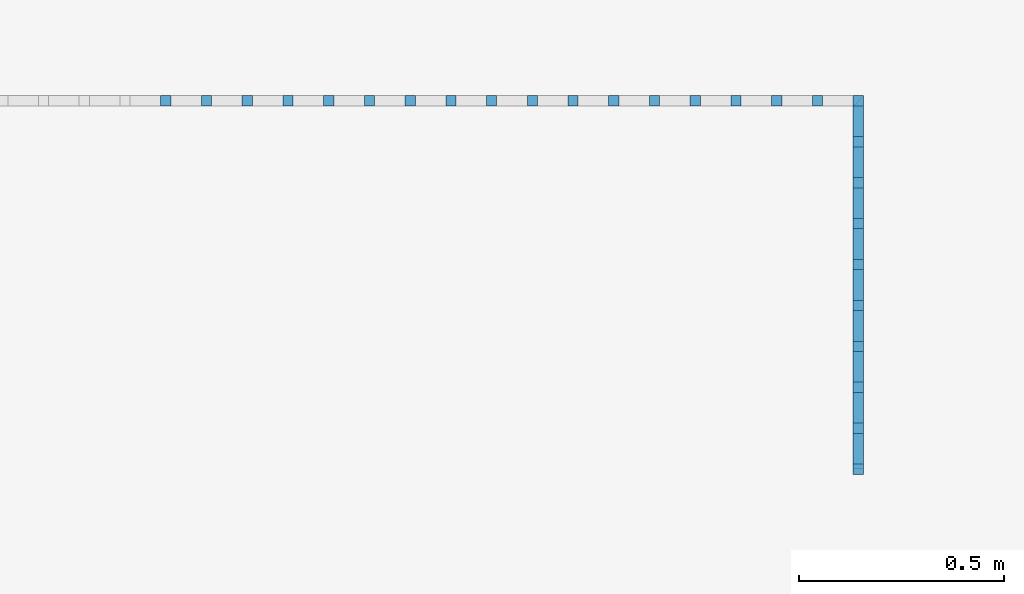
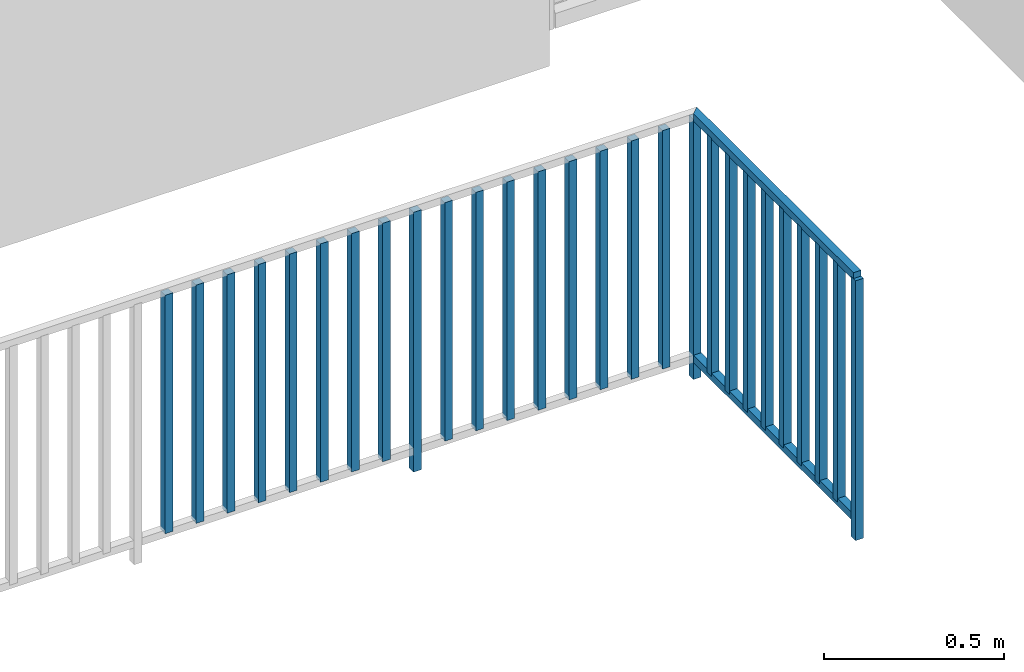
# One storey, part 41 of 54: 29 building element parts, 1 element without a shape of its own.
"""IFC4 building model written with IfcOpenShell, lengths in metres."""

from ifc_helpers import new_model, entity, si_unit, converted_unit, derived_unit, direction, frame, origin_with_axes, place, context, subcontext, project, spatial, polygons, material, type_object, element, aggregate, save


model = new_model("IFC4")

# Units and contexts
model_context = context("Model", 3, precision=1e-05, world=origin_with_axes(), true_north=direction((0.0, 1.0)))
body_context = subcontext(model_context, "Body", "Model", "MODEL_VIEW")
ifc_project = project(units=[si_unit("LENGTHUNIT", "METRE"), si_unit("AREAUNIT", "SQUARE_METRE"), si_unit("VOLUMEUNIT", "CUBIC_METRE"), converted_unit("PLANEANGLEUNIT", "DEGREE", entity("IfcPlaneAngleMeasure", 0.0174532925199), si_unit("PLANEANGLEUNIT", "RADIAN"), dimensions=[0, 0, 0, 0, 0, 0, 0]), converted_unit("TIMEUNIT", "Year", entity("IfcTimeMeasure", 31556926.0), si_unit("TIMEUNIT", "SECOND"), dimensions=[0, 0, 1, 0, 0, 0, 0]), si_unit("MASSUNIT", "GRAM", prefix="KILO"), si_unit("THERMODYNAMICTEMPERATUREUNIT", "DEGREE_CELSIUS"), si_unit("LUMINOUSINTENSITYUNIT", "LUMEN"), si_unit("ENERGYUNIT", "JOULE", prefix="MEGA"), derived_unit("THERMALCONDUCTANCEUNIT", [(si_unit("POWERUNIT", "WATT"), 1), (si_unit("LENGTHUNIT", "METRE"), -1), (si_unit("THERMODYNAMICTEMPERATUREUNIT", "KELVIN"), -1)]), derived_unit("SPECIFICHEATCAPACITYUNIT", [(si_unit("ENERGYUNIT", "JOULE"), 1), (si_unit("MASSUNIT", "GRAM", prefix="KILO"), -1), (si_unit("THERMODYNAMICTEMPERATUREUNIT", "KELVIN"), -1)]), derived_unit("MASSDENSITYUNIT", [(si_unit("MASSUNIT", "GRAM", prefix="KILO"), 1), (si_unit("VOLUMEUNIT", "CUBIC_METRE"), -1)])], contexts=[model_context])

# Site, building, storey, space
site_placement = place(None, origin_with_axes())
site = spatial("IfcSite", under=ifc_project, at=site_placement, CompositionType="ELEMENT")
building_placement = place(site_placement, origin_with_axes())
building = spatial("IfcBuilding", under=site, at=building_placement, CompositionType="ELEMENT")
storey_placement = place(building_placement, frame((0.0, 0.0, 9.18), z_axis=(0.0, 0.0, 1.0), x_axis=(1.0, 0.0, 0.0)))
storey = spatial("IfcBuildingStorey", under=building, at=storey_placement, Name="3. Geschoss", CompositionType="ELEMENT", Elevation=9.18)
space_placement = place(storey_placement, frame((-3.4421993804, -2.52881223104, 0.0), z_axis=(0.0, 0.0, 1.0), x_axis=(1.0, 0.0, 0.0)))
space = spatial("IfcSpace", under=storey, at=space_placement, CompositionType="ELEMENT", PredefinedType="INTERNAL")

# Railing, building element parts
railing_type = type_object("IfcRailingType", PredefinedType="NOTDEFINED")
railing_placement = place(space_placement, frame((0.0, 1.5, 0.0), z_axis=(0.0, 0.0, 1.0), x_axis=(1.0, 0.0, 0.0)))
railing = element("IfcRailing", 1, at=railing_placement, inside=space, type_object=railing_type, PredefinedType="NOTDEFINED")
ifc_material = material()
building_element_part_1_placement = place(railing_placement, origin_with_axes())
building_element_part_1 = element("IfcBuildingElementPart", 2, at=building_element_part_1_placement, material=ifc_material, PredefinedType="NOTDEFINED", context=body_context, shape_type="Tessellation", body=[
    polygons([(4.4925, 0.8875, 0.0), (4.4925, 0.9125, 0.0), (4.4925, 0.9125, 0.88), (4.4925, 0.8875, 0.88), (4.4675, 0.8875, 0.0), (4.4675, 0.9125, 0.0), (4.4675, 0.9125, 0.88), (4.4675, 0.8875, 0.88)], [[[1, 2, 3, 4]], [[1, 5, 6, 2]], [[2, 6, 7, 3]], [[4, 3, 7, 8]], [[5, 1, 4, 8]], [[6, 5, 8, 7]]], closed=True),
])
building_element_part_2_placement = place(railing_placement, origin_with_axes())
building_element_part_2 = element("IfcBuildingElementPart", 3, at=building_element_part_2_placement, material=ifc_material, PredefinedType="NOTDEFINED", context=body_context, shape_type="Tessellation", body=[
    polygons([(4.4675, -0.0125, 0.0), (4.4925, -0.0125, 0.0), (4.4925, -0.0125, 0.88), (4.4675, -0.0125, 0.88), (4.4675, 0.0125, 0.0), (4.4925, 0.0125, 0.0), (4.4925, 0.0125, 0.88), (4.4675, 0.0125, 0.88)], [[[1, 2, 3, 4]], [[1, 5, 6, 2]], [[2, 6, 7, 3]], [[4, 3, 7, 8]], [[5, 1, 4, 8]], [[6, 5, 8, 7]]], closed=True),
])
building_element_part_3_placement = place(railing_placement, origin_with_axes())
building_element_part_3 = element("IfcBuildingElementPart", 4, at=building_element_part_3_placement, material=ifc_material, PredefinedType="NOTDEFINED", context=body_context, shape_type="Tessellation", body=[
    polygons([(2.80005555556, 0.8875, 0.07), (2.80005555556, 0.9125, 0.07), (2.80005555556, 0.9125, 0.8775), (2.80005555556, 0.8875, 0.8775), (2.77505555556, 0.8875, 0.07), (2.77505555556, 0.9125, 0.07), (2.77505555556, 0.9125, 0.8775), (2.77505555556, 0.8875, 0.8775)], [[[1, 2, 3, 4]], [[1, 5, 6, 2]], [[2, 6, 7, 3]], [[4, 3, 7, 8]], [[5, 1, 4, 8]], [[6, 5, 8, 7]]], closed=True),
])
building_element_part_4_placement = place(railing_placement, origin_with_axes())
building_element_part_4 = element("IfcBuildingElementPart", 5, at=building_element_part_4_placement, material=ifc_material, PredefinedType="NOTDEFINED", context=body_context, shape_type="Tessellation", body=[
    polygons([(2.89961111111, 0.8875, 0.07), (2.89961111111, 0.9125, 0.07), (2.89961111111, 0.9125, 0.8775), (2.89961111111, 0.8875, 0.8775), (2.87461111111, 0.8875, 0.07), (2.87461111111, 0.9125, 0.07), (2.87461111111, 0.9125, 0.8775), (2.87461111111, 0.8875, 0.8775)], [[[1, 2, 3, 4]], [[1, 5, 6, 2]], [[2, 6, 7, 3]], [[4, 3, 7, 8]], [[5, 1, 4, 8]], [[6, 5, 8, 7]]], closed=True),
])
building_element_part_5_placement = place(railing_placement, origin_with_axes())
building_element_part_5 = element("IfcBuildingElementPart", 6, at=building_element_part_5_placement, material=ifc_material, PredefinedType="NOTDEFINED", context=body_context, shape_type="Tessellation", body=[
    polygons([(2.99916666667, 0.8875, 0.07), (2.99916666667, 0.9125, 0.07), (2.99916666667, 0.9125, 0.8775), (2.99916666667, 0.8875, 0.8775), (2.97416666667, 0.8875, 0.07), (2.97416666667, 0.9125, 0.07), (2.97416666667, 0.9125, 0.8775), (2.97416666667, 0.8875, 0.8775)], [[[1, 2, 3, 4]], [[1, 5, 6, 2]], [[2, 6, 7, 3]], [[4, 3, 7, 8]], [[5, 1, 4, 8]], [[6, 5, 8, 7]]], closed=True),
])
building_element_part_6_placement = place(railing_placement, origin_with_axes())
building_element_part_6 = element("IfcBuildingElementPart", 7, at=building_element_part_6_placement, material=ifc_material, PredefinedType="NOTDEFINED", context=body_context, shape_type="Tessellation", body=[
    polygons([(3.09872222222, 0.8875, 0.07), (3.09872222222, 0.9125, 0.07), (3.09872222222, 0.9125, 0.8775), (3.09872222222, 0.8875, 0.8775), (3.07372222222, 0.8875, 0.07), (3.07372222222, 0.9125, 0.07), (3.07372222222, 0.9125, 0.8775), (3.07372222222, 0.8875, 0.8775)], [[[1, 2, 3, 4]], [[1, 5, 6, 2]], [[2, 6, 7, 3]], [[4, 3, 7, 8]], [[5, 1, 4, 8]], [[6, 5, 8, 7]]], closed=True),
])
building_element_part_7_placement = place(railing_placement, origin_with_axes())
building_element_part_7 = element("IfcBuildingElementPart", 8, at=building_element_part_7_placement, material=ifc_material, PredefinedType="NOTDEFINED", context=body_context, shape_type="Tessellation", body=[
    polygons([(3.19827777778, 0.8875, 0.07), (3.19827777778, 0.9125, 0.07), (3.19827777778, 0.9125, 0.8775), (3.19827777778, 0.8875, 0.8775), (3.17327777778, 0.8875, 0.07), (3.17327777778, 0.9125, 0.07), (3.17327777778, 0.9125, 0.8775), (3.17327777778, 0.8875, 0.8775)], [[[1, 2, 3, 4]], [[1, 5, 6, 2]], [[2, 6, 7, 3]], [[4, 3, 7, 8]], [[5, 1, 4, 8]], [[6, 5, 8, 7]]], closed=True),
])
building_element_part_8_placement = place(railing_placement, origin_with_axes())
building_element_part_8 = element("IfcBuildingElementPart", 9, at=building_element_part_8_placement, material=ifc_material, PredefinedType="NOTDEFINED", context=body_context, shape_type="Tessellation", body=[
    polygons([(3.29783333333, 0.8875, 0.07), (3.29783333333, 0.9125, 0.07), (3.29783333333, 0.9125, 0.8775), (3.29783333333, 0.8875, 0.8775), (3.27283333333, 0.8875, 0.07), (3.27283333333, 0.9125, 0.07), (3.27283333333, 0.9125, 0.8775), (3.27283333333, 0.8875, 0.8775)], [[[1, 2, 3, 4]], [[1, 5, 6, 2]], [[2, 6, 7, 3]], [[4, 3, 7, 8]], [[5, 1, 4, 8]], [[6, 5, 8, 7]]], closed=True),
])
building_element_part_9_placement = place(railing_placement, origin_with_axes())
building_element_part_9 = element("IfcBuildingElementPart", 10, at=building_element_part_9_placement, material=ifc_material, PredefinedType="NOTDEFINED", context=body_context, shape_type="Tessellation", body=[
    polygons([(3.39738888889, 0.8875, 0.07), (3.39738888889, 0.9125, 0.07), (3.39738888889, 0.9125, 0.8775), (3.39738888889, 0.8875, 0.8775), (3.37238888889, 0.8875, 0.07), (3.37238888889, 0.9125, 0.07), (3.37238888889, 0.9125, 0.8775), (3.37238888889, 0.8875, 0.8775)], [[[1, 2, 3, 4]], [[1, 5, 6, 2]], [[2, 6, 7, 3]], [[4, 3, 7, 8]], [[5, 1, 4, 8]], [[6, 5, 8, 7]]], closed=True),
])
building_element_part_10_placement = place(railing_placement, origin_with_axes())
building_element_part_10 = element("IfcBuildingElementPart", 11, at=building_element_part_10_placement, material=ifc_material, PredefinedType="NOTDEFINED", context=body_context, shape_type="Tessellation", body=[
    polygons([(3.49694444444, 0.8875, 0.07), (3.49694444444, 0.9125, 0.07), (3.49694444444, 0.9125, 0.8775), (3.49694444444, 0.8875, 0.8775), (3.47194444444, 0.8875, 0.07), (3.47194444444, 0.9125, 0.07), (3.47194444444, 0.9125, 0.8775), (3.47194444444, 0.8875, 0.8775)], [[[1, 2, 3, 4]], [[1, 5, 6, 2]], [[2, 6, 7, 3]], [[4, 3, 7, 8]], [[5, 1, 4, 8]], [[6, 5, 8, 7]]], closed=True),
])
building_element_part_11_placement = place(railing_placement, origin_with_axes())
building_element_part_11 = element("IfcBuildingElementPart", 12, at=building_element_part_11_placement, material=ifc_material, PredefinedType="NOTDEFINED", context=body_context, shape_type="Tessellation", body=[
    polygons([(3.5965, 0.8875, 0.0), (3.5965, 0.9125, 0.0), (3.5965, 0.9125, 0.88), (3.5965, 0.8875, 0.88), (3.5715, 0.8875, 0.0), (3.5715, 0.9125, 0.0), (3.5715, 0.9125, 0.88), (3.5715, 0.8875, 0.88)], [[[1, 2, 3, 4]], [[1, 5, 6, 2]], [[2, 6, 7, 3]], [[4, 3, 7, 8]], [[5, 1, 4, 8]], [[6, 5, 8, 7]]], closed=True),
])
building_element_part_12_placement = place(railing_placement, origin_with_axes())
building_element_part_12 = element("IfcBuildingElementPart", 13, at=building_element_part_12_placement, material=ifc_material, PredefinedType="NOTDEFINED", context=body_context, shape_type="Tessellation", body=[
    polygons([(3.69605555556, 0.8875, 0.07), (3.69605555556, 0.9125, 0.07), (3.69605555556, 0.9125, 0.8775), (3.69605555556, 0.8875, 0.8775), (3.67105555556, 0.8875, 0.07), (3.67105555556, 0.9125, 0.07), (3.67105555556, 0.9125, 0.8775), (3.67105555556, 0.8875, 0.8775)], [[[1, 2, 3, 4]], [[1, 5, 6, 2]], [[2, 6, 7, 3]], [[4, 3, 7, 8]], [[5, 1, 4, 8]], [[6, 5, 8, 7]]], closed=True),
])
building_element_part_13_placement = place(railing_placement, origin_with_axes())
building_element_part_13 = element("IfcBuildingElementPart", 14, at=building_element_part_13_placement, material=ifc_material, PredefinedType="NOTDEFINED", context=body_context, shape_type="Tessellation", body=[
    polygons([(3.79561111111, 0.8875, 0.07), (3.79561111111, 0.9125, 0.07), (3.79561111111, 0.9125, 0.8775), (3.79561111111, 0.8875, 0.8775), (3.77061111111, 0.8875, 0.07), (3.77061111111, 0.9125, 0.07), (3.77061111111, 0.9125, 0.8775), (3.77061111111, 0.8875, 0.8775)], [[[1, 2, 3, 4]], [[1, 5, 6, 2]], [[2, 6, 7, 3]], [[4, 3, 7, 8]], [[5, 1, 4, 8]], [[6, 5, 8, 7]]], closed=True),
])
building_element_part_14_placement = place(railing_placement, origin_with_axes())
building_element_part_14 = element("IfcBuildingElementPart", 15, at=building_element_part_14_placement, material=ifc_material, PredefinedType="NOTDEFINED", context=body_context, shape_type="Tessellation", body=[
    polygons([(3.89516666667, 0.8875, 0.07), (3.89516666667, 0.9125, 0.07), (3.89516666667, 0.9125, 0.8775), (3.89516666667, 0.8875, 0.8775), (3.87016666667, 0.8875, 0.07), (3.87016666667, 0.9125, 0.07), (3.87016666667, 0.9125, 0.8775), (3.87016666667, 0.8875, 0.8775)], [[[1, 2, 3, 4]], [[1, 5, 6, 2]], [[2, 6, 7, 3]], [[4, 3, 7, 8]], [[5, 1, 4, 8]], [[6, 5, 8, 7]]], closed=True),
])
building_element_part_15_placement = place(railing_placement, origin_with_axes())
building_element_part_15 = element("IfcBuildingElementPart", 16, at=building_element_part_15_placement, material=ifc_material, PredefinedType="NOTDEFINED", context=body_context, shape_type="Tessellation", body=[
    polygons([(3.99472222222, 0.8875, 0.07), (3.99472222222, 0.9125, 0.07), (3.99472222222, 0.9125, 0.8775), (3.99472222222, 0.8875, 0.8775), (3.96972222222, 0.8875, 0.07), (3.96972222222, 0.9125, 0.07), (3.96972222222, 0.9125, 0.8775), (3.96972222222, 0.8875, 0.8775)], [[[1, 2, 3, 4]], [[1, 5, 6, 2]], [[2, 6, 7, 3]], [[4, 3, 7, 8]], [[5, 1, 4, 8]], [[6, 5, 8, 7]]], closed=True),
])
building_element_part_16_placement = place(railing_placement, origin_with_axes())
building_element_part_16 = element("IfcBuildingElementPart", 17, at=building_element_part_16_placement, material=ifc_material, PredefinedType="NOTDEFINED", context=body_context, shape_type="Tessellation", body=[
    polygons([(4.09427777778, 0.8875, 0.07), (4.09427777778, 0.9125, 0.07), (4.09427777778, 0.9125, 0.8775), (4.09427777778, 0.8875, 0.8775), (4.06927777778, 0.8875, 0.07), (4.06927777778, 0.9125, 0.07), (4.06927777778, 0.9125, 0.8775), (4.06927777778, 0.8875, 0.8775)], [[[1, 2, 3, 4]], [[1, 5, 6, 2]], [[2, 6, 7, 3]], [[4, 3, 7, 8]], [[5, 1, 4, 8]], [[6, 5, 8, 7]]], closed=True),
])
building_element_part_17_placement = place(railing_placement, origin_with_axes())
building_element_part_17 = element("IfcBuildingElementPart", 18, at=building_element_part_17_placement, material=ifc_material, PredefinedType="NOTDEFINED", context=body_context, shape_type="Tessellation", body=[
    polygons([(4.19383333333, 0.8875, 0.07), (4.19383333333, 0.9125, 0.07), (4.19383333333, 0.9125, 0.8775), (4.19383333333, 0.8875, 0.8775), (4.16883333333, 0.8875, 0.07), (4.16883333333, 0.9125, 0.07), (4.16883333333, 0.9125, 0.8775), (4.16883333333, 0.8875, 0.8775)], [[[1, 2, 3, 4]], [[1, 5, 6, 2]], [[2, 6, 7, 3]], [[4, 3, 7, 8]], [[5, 1, 4, 8]], [[6, 5, 8, 7]]], closed=True),
])
building_element_part_18_placement = place(railing_placement, origin_with_axes())
building_element_part_18 = element("IfcBuildingElementPart", 19, at=building_element_part_18_placement, material=ifc_material, PredefinedType="NOTDEFINED", context=body_context, shape_type="Tessellation", body=[
    polygons([(4.29338888889, 0.8875, 0.07), (4.29338888889, 0.9125, 0.07), (4.29338888889, 0.9125, 0.8775), (4.29338888889, 0.8875, 0.8775), (4.26838888889, 0.8875, 0.07), (4.26838888889, 0.9125, 0.07), (4.26838888889, 0.9125, 0.8775), (4.26838888889, 0.8875, 0.8775)], [[[1, 2, 3, 4]], [[1, 5, 6, 2]], [[2, 6, 7, 3]], [[4, 3, 7, 8]], [[5, 1, 4, 8]], [[6, 5, 8, 7]]], closed=True),
])
building_element_part_19_placement = place(railing_placement, origin_with_axes())
building_element_part_19 = element("IfcBuildingElementPart", 20, at=building_element_part_19_placement, material=ifc_material, PredefinedType="NOTDEFINED", context=body_context, shape_type="Tessellation", body=[
    polygons([(4.39294444444, 0.8875, 0.07), (4.39294444444, 0.9125, 0.07), (4.39294444444, 0.9125, 0.8775), (4.39294444444, 0.8875, 0.8775), (4.36794444444, 0.8875, 0.07), (4.36794444444, 0.9125, 0.07), (4.36794444444, 0.9125, 0.8775), (4.36794444444, 0.8875, 0.8775)], [[[1, 2, 3, 4]], [[1, 5, 6, 2]], [[2, 6, 7, 3]], [[4, 3, 7, 8]], [[5, 1, 4, 8]], [[6, 5, 8, 7]]], closed=True),
])
building_element_part_20_placement = place(railing_placement, origin_with_axes())
building_element_part_20 = element("IfcBuildingElementPart", 21, at=building_element_part_20_placement, material=ifc_material, PredefinedType="NOTDEFINED", context=body_context, shape_type="Tessellation", body=[
    polygons([(4.4675, 0.8875, 0.9), (4.4675, 0.8875, 0.875), (4.4675, 0.0, 0.875), (4.4675, 0.0, 0.9), (4.4925, 0.9125, 0.9), (4.4925, 0.9125, 0.875), (4.4925, 0.0, 0.875), (4.4925, 0.0, 0.9)], [[[1, 2, 3, 4]], [[1, 5, 6, 2]], [[2, 6, 7, 3]], [[4, 3, 7, 8]], [[5, 1, 4, 8]], [[6, 5, 8, 7]]], closed=True),
])
building_element_part_21_placement = place(railing_placement, origin_with_axes())
building_element_part_21 = element("IfcBuildingElementPart", 22, at=building_element_part_21_placement, material=ifc_material, PredefinedType="NOTDEFINED", context=body_context, shape_type="Tessellation", body=[
    polygons([(4.4675, 0.8875, 0.0825), (4.4675, 0.8875, 0.0575), (4.4675, 0.0, 0.0575), (4.4675, 0.0, 0.0825), (4.4925, 0.9125, 0.0825), (4.4925, 0.9125, 0.0575), (4.4925, 0.0, 0.0575), (4.4925, 0.0, 0.0825)], [[[1, 2, 3, 4]], [[1, 5, 6, 2]], [[2, 6, 7, 3]], [[4, 3, 7, 8]], [[5, 1, 4, 8]], [[6, 5, 8, 7]]], closed=True),
])
building_element_part_22_placement = place(railing_placement, origin_with_axes())
building_element_part_22 = element("IfcBuildingElementPart", 23, at=building_element_part_22_placement, material=ifc_material, PredefinedType="NOTDEFINED", context=body_context, shape_type="Tessellation", body=[
    polygons([(4.4675, 0.7875, 0.07), (4.4925, 0.7875, 0.07), (4.4925, 0.7875, 0.8775), (4.4675, 0.7875, 0.8775), (4.4675, 0.8125, 0.07), (4.4925, 0.8125, 0.07), (4.4925, 0.8125, 0.8775), (4.4675, 0.8125, 0.8775)], [[[1, 2, 3, 4]], [[1, 5, 6, 2]], [[2, 6, 7, 3]], [[4, 3, 7, 8]], [[5, 1, 4, 8]], [[6, 5, 8, 7]]], closed=True),
])
building_element_part_23_placement = place(railing_placement, origin_with_axes())
building_element_part_23 = element("IfcBuildingElementPart", 24, at=building_element_part_23_placement, material=ifc_material, PredefinedType="NOTDEFINED", context=body_context, shape_type="Tessellation", body=[
    polygons([(4.4675, 0.6875, 0.07), (4.4925, 0.6875, 0.07), (4.4925, 0.6875, 0.8775), (4.4675, 0.6875, 0.8775), (4.4675, 0.7125, 0.07), (4.4925, 0.7125, 0.07), (4.4925, 0.7125, 0.8775), (4.4675, 0.7125, 0.8775)], [[[1, 2, 3, 4]], [[1, 5, 6, 2]], [[2, 6, 7, 3]], [[4, 3, 7, 8]], [[5, 1, 4, 8]], [[6, 5, 8, 7]]], closed=True),
])
building_element_part_24_placement = place(railing_placement, origin_with_axes())
building_element_part_24 = element("IfcBuildingElementPart", 25, at=building_element_part_24_placement, material=ifc_material, PredefinedType="NOTDEFINED", context=body_context, shape_type="Tessellation", body=[
    polygons([(4.4675, 0.5875, 0.07), (4.4925, 0.5875, 0.07), (4.4925, 0.5875, 0.8775), (4.4675, 0.5875, 0.8775), (4.4675, 0.6125, 0.07), (4.4925, 0.6125, 0.07), (4.4925, 0.6125, 0.8775), (4.4675, 0.6125, 0.8775)], [[[1, 2, 3, 4]], [[1, 5, 6, 2]], [[2, 6, 7, 3]], [[4, 3, 7, 8]], [[5, 1, 4, 8]], [[6, 5, 8, 7]]], closed=True),
])
building_element_part_25_placement = place(railing_placement, origin_with_axes())
building_element_part_25 = element("IfcBuildingElementPart", 26, at=building_element_part_25_placement, material=ifc_material, PredefinedType="NOTDEFINED", context=body_context, shape_type="Tessellation", body=[
    polygons([(4.4675, 0.4875, 0.07), (4.4925, 0.4875, 0.07), (4.4925, 0.4875, 0.8775), (4.4675, 0.4875, 0.8775), (4.4675, 0.5125, 0.07), (4.4925, 0.5125, 0.07), (4.4925, 0.5125, 0.8775), (4.4675, 0.5125, 0.8775)], [[[1, 2, 3, 4]], [[1, 5, 6, 2]], [[2, 6, 7, 3]], [[4, 3, 7, 8]], [[5, 1, 4, 8]], [[6, 5, 8, 7]]], closed=True),
])
building_element_part_26_placement = place(railing_placement, origin_with_axes())
building_element_part_26 = element("IfcBuildingElementPart", 27, at=building_element_part_26_placement, material=ifc_material, PredefinedType="NOTDEFINED", context=body_context, shape_type="Tessellation", body=[
    polygons([(4.4675, 0.3875, 0.07), (4.4925, 0.3875, 0.07), (4.4925, 0.3875, 0.8775), (4.4675, 0.3875, 0.8775), (4.4675, 0.4125, 0.07), (4.4925, 0.4125, 0.07), (4.4925, 0.4125, 0.8775), (4.4675, 0.4125, 0.8775)], [[[1, 2, 3, 4]], [[1, 5, 6, 2]], [[2, 6, 7, 3]], [[4, 3, 7, 8]], [[5, 1, 4, 8]], [[6, 5, 8, 7]]], closed=True),
])
building_element_part_27_placement = place(railing_placement, origin_with_axes())
building_element_part_27 = element("IfcBuildingElementPart", 28, at=building_element_part_27_placement, material=ifc_material, PredefinedType="NOTDEFINED", context=body_context, shape_type="Tessellation", body=[
    polygons([(4.4675, 0.2875, 0.07), (4.4925, 0.2875, 0.07), (4.4925, 0.2875, 0.8775), (4.4675, 0.2875, 0.8775), (4.4675, 0.3125, 0.07), (4.4925, 0.3125, 0.07), (4.4925, 0.3125, 0.8775), (4.4675, 0.3125, 0.8775)], [[[1, 2, 3, 4]], [[1, 5, 6, 2]], [[2, 6, 7, 3]], [[4, 3, 7, 8]], [[5, 1, 4, 8]], [[6, 5, 8, 7]]], closed=True),
])
building_element_part_28_placement = place(railing_placement, origin_with_axes())
building_element_part_28 = element("IfcBuildingElementPart", 29, at=building_element_part_28_placement, material=ifc_material, PredefinedType="NOTDEFINED", context=body_context, shape_type="Tessellation", body=[
    polygons([(4.4675, 0.1875, 0.07), (4.4925, 0.1875, 0.07), (4.4925, 0.1875, 0.8775), (4.4675, 0.1875, 0.8775), (4.4675, 0.2125, 0.07), (4.4925, 0.2125, 0.07), (4.4925, 0.2125, 0.8775), (4.4675, 0.2125, 0.8775)], [[[1, 2, 3, 4]], [[1, 5, 6, 2]], [[2, 6, 7, 3]], [[4, 3, 7, 8]], [[5, 1, 4, 8]], [[6, 5, 8, 7]]], closed=True),
])
building_element_part_29_placement = place(railing_placement, origin_with_axes())
building_element_part_29 = element("IfcBuildingElementPart", 30, at=building_element_part_29_placement, material=ifc_material, PredefinedType="NOTDEFINED", context=body_context, shape_type="Tessellation", body=[
    polygons([(4.4675, 0.0875, 0.07), (4.4925, 0.0875, 0.07), (4.4925, 0.0875, 0.8775), (4.4675, 0.0875, 0.8775), (4.4675, 0.1125, 0.07), (4.4925, 0.1125, 0.07), (4.4925, 0.1125, 0.8775), (4.4675, 0.1125, 0.8775)], [[[1, 2, 3, 4]], [[1, 5, 6, 2]], [[2, 6, 7, 3]], [[4, 3, 7, 8]], [[5, 1, 4, 8]], [[6, 5, 8, 7]]], closed=True),
])
aggregate(railing, [building_element_part_1, building_element_part_2, building_element_part_3, building_element_part_4, building_element_part_5, building_element_part_6, building_element_part_7, building_element_part_8, building_element_part_9, building_element_part_10, building_element_part_11, building_element_part_12, building_element_part_13, building_element_part_14, building_element_part_15, building_element_part_16, building_element_part_17, building_element_part_18, building_element_part_19, building_element_part_20, building_element_part_21, building_element_part_22, building_element_part_23, building_element_part_24, building_element_part_25, building_element_part_26, building_element_part_27, building_element_part_28, building_element_part_29])

save(model, "model.ifc")
